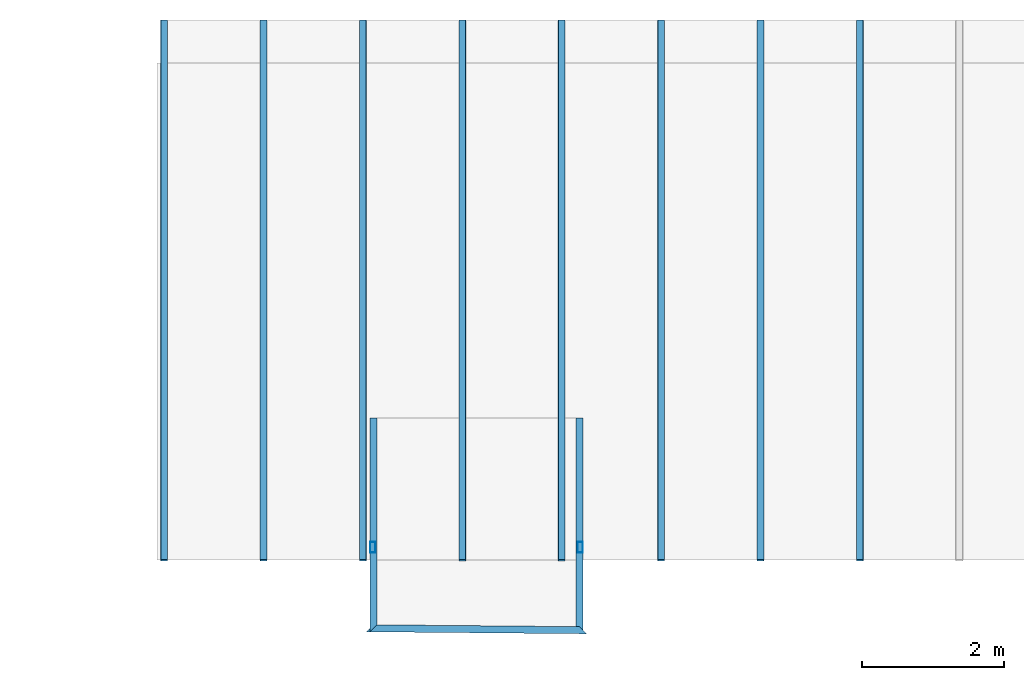
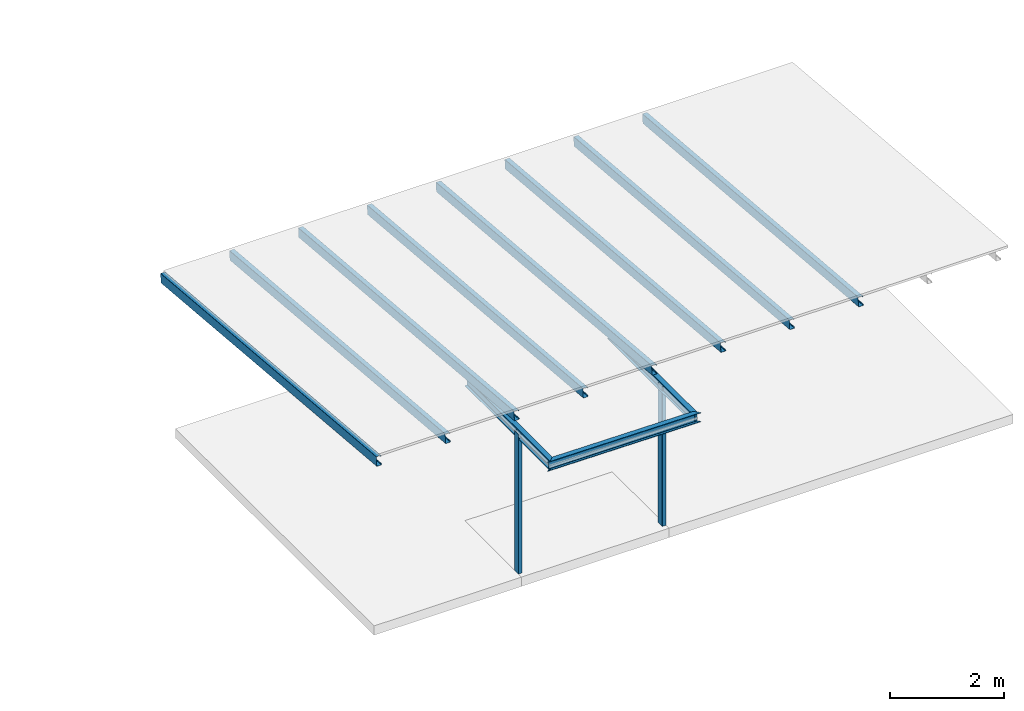
# One storey, part 3 of 8: 11 beams, 2 columns.
"""IFC4 building model written with IfcOpenShell, lengths in metres."""

from ifc_helpers import new_model, si_unit, frame, origin_with_axes, origin_2d_with_axis, place, context, subcontext, project, spatial, hollow_rectangle, i_section, c_section, extrude, clip, halfspace, material, material_profile, profile_set, profile_usage, type_object, element, save


model = new_model("IFC4")

# Units and contexts
model_context = context("Model", 3, precision=1e-05, world=origin_with_axes())
plan_context = context("Plan", 2, precision=1e-05, world=origin_2d_with_axis())
body_context = subcontext(model_context, "Body", "Model", "MODEL_VIEW")
ifc_project = project(units=[si_unit("VOLUMEUNIT", "CUBIC_METRE"), si_unit("LENGTHUNIT", "METRE"), si_unit("AREAUNIT", "SQUARE_METRE")], contexts=[model_context, plan_context])

# Site, building, storey
site_placement = place(None, origin_with_axes())
site = spatial("IfcSite", under=ifc_project, at=site_placement)
building_placement = place(site_placement, origin_with_axes())
building = spatial("IfcBuilding", under=site, at=building_placement, Name="Building")
storey_placement = place(building_placement, frame((0.0, 0.0, 7.0), z_axis=(0.0, 0.0, 1.0), x_axis=(1.0, 0.0, 0.0)))
storey = spatial("IfcBuildingStorey", under=building, at=storey_placement, Name="Level 2")

# Columns
ifc_material = material()
ifc_material_profile_1 = material_profile(ifc_material, hollow_rectangle(XDim=0.075, YDim=0.15, WallThickness=0.002, InnerFilletRadius=0.005, OuterFilletRadius=0.005))
ifc_profile_set_1 = profile_set([ifc_material_profile_1])
ifc_profile_usage_1 = profile_usage(ifc_profile_set_1, cardinal=5)
column_type = type_object("IfcColumnType", Name="C3", PredefinedType="NOTDEFINED", material=ifc_profile_set_1)
column_1_placement = place(storey_placement, frame((-0.03749847412109375, 0.18234758079051971, -7.0), z_axis=(0.0, 0.0, 1.0), x_axis=(1.0, 0.0, 0.0)))
element("IfcColumn", 1, at=column_1_placement, inside=storey, type_object=column_type, material=ifc_profile_usage_1, Name="Column", context=body_context, shape_type="SweptSolid", body=[
    extrude(hollow_rectangle(XDim=0.075, YDim=0.15, WallThickness=0.002, InnerFilletRadius=0.005, OuterFilletRadius=0.005), origin_with_axes(), (0.0, 0.0, 1.0), 3.0),
])
ifc_profile_usage_2 = profile_usage(ifc_profile_set_1, cardinal=5)
column_2_placement = place(storey_placement, frame((-2.962498188018799, 0.18234653770923615, -7.000000208616257), z_axis=(0.0, 0.0, 1.0), x_axis=(1.0, 0.0, 0.0)))
element("IfcColumn", 2, at=column_2_placement, inside=storey, type_object=column_type, material=ifc_profile_usage_2, Name="Column", context=body_context, shape_type="SweptSolid", body=[
    extrude(hollow_rectangle(XDim=0.075, YDim=0.15, WallThickness=0.002, InnerFilletRadius=0.005, OuterFilletRadius=0.005), origin_with_axes(), (0.0, 0.0, 1.0), 3.0),
])

# Beams
ifc_material_profile_2 = material_profile(ifc_material, i_section(OverallWidth=0.1, OverallDepth=0.2, WebThickness=0.005, FlangeThickness=0.01, FilletRadius=0.005))
ifc_profile_set_2 = profile_set([ifc_material_profile_2])
ifc_profile_usage_3 = profile_usage(ifc_profile_set_2, cardinal=5)
beam_type_1 = type_object("IfcBeamType", Name="B1", PredefinedType="NOTDEFINED", material=ifc_profile_set_2)
beam_1_placement = place(storey_placement, frame((-2.950000286102295, 1.9999995231628418, -4.0), z_axis=(2.4169833068297445e-07, -0.9999999999999216, 3.1391647326015385e-07), x_axis=(0.9999999999999709, 2.4169833068298636e-07, -7.089306626548652e-14)))
element("IfcBeam", 3, at=beam_1_placement, inside=storey, type_object=beam_type_1, material=ifc_profile_usage_3, Name="Beam", context=body_context, shape_type="Clipping", body=[
    clip(extrude(i_section(OverallWidth=0.1, OverallDepth=0.2, WebThickness=0.005, FlangeThickness=0.01, FilletRadius=0.005), origin_with_axes(), (0.0, 0.0, 1.0), 3.2092926936012094), halfspace(frame((-0.04999971762299538, -3.0000011920928955, 3.0088346004486084), z_axis=(0.7038670182228088, -2.0181441584554705e-07, 0.7103317379951477), x_axis=(-2.8672236462378816e-07, -0.9999999999999588, 0.0)), False)),
])
ifc_profile_usage_4 = profile_usage(ifc_profile_set_2, cardinal=5)
beam_2_placement = place(storey_placement, frame((-3.2499897480010986, -0.9570047855377197, -3.999981641769409), z_axis=(0.9999581920805248, -0.009143776962454424, -7.371505304809526e-05), x_axis=(0.009143776987297651, 0.9999581947973658, -9.677141538333073e-09)))
element("IfcBeam", 4, at=beam_2_placement, inside=storey, type_object=beam_type_1, material=ifc_profile_usage_4, Name="Beam", context=body_context, shape_type="Clipping", body=[
    clip(clip(extrude(i_section(OverallWidth=0.1, OverallDepth=0.2, WebThickness=0.005, FlangeThickness=0.01, FilletRadius=0.005), origin_with_axes(), (0.0, 0.0, 1.0), 3.5001288946107785), halfspace(frame((-0.049999918788671494, -2.9997751712799072, 3.300807476043701), z_axis=(0.7103319764137268, 5.187707574805245e-05, 0.7038668394088745), x_axis=(7.303215585424923e-05, -0.9999999973331521, 0.0)), False)), halfspace(frame((-0.050000037997961044, -3.0000035762786865, 0.2006784975528717), z_axis=(0.7038658261299133, -5.2376588428160176e-05, -0.7103329300880432), x_axis=(-7.441274506979924e-05, -0.9999999972313717, 0.0)), False)),
])
ifc_profile_usage_5 = profile_usage(ifc_profile_set_2, cardinal=5)
beam_3_placement = place(storey_placement, frame((-0.04999832063913345, -1.2367253303527832, -4.000239849090576), z_axis=(-1.509963847598649e-07, 0.9999999972630798, 7.39852546551974e-05), x_axis=(-0.9999999999999887, -1.5099580252808492e-07, -7.949847002919252e-09)))
element("IfcBeam", 5, at=beam_3_placement, inside=storey, type_object=beam_type_1, material=ifc_profile_usage_5, Name="Beam", context=body_context, shape_type="Clipping", body=[
    clip(extrude(i_section(OverallWidth=0.1, OverallDepth=0.2, WebThickness=0.005, FlangeThickness=0.01, FilletRadius=0.005), origin_with_axes(), (0.0, 0.0, 1.0), 3.236725777241487), halfspace(frame((-0.04999999701976776, -2.9997756481170654, 0.19932077825069427), z_axis=(0.710332989692688, 5.209675509831868e-05, -0.7038663029670715), x_axis=(7.334131416414219e-05, -0.9999999973105258, 0.0)), False)),
])
ifc_material_profile_3 = material_profile(ifc_material, c_section(Depth=0.2, Width=0.1, WallThickness=0.0015, Girth=0.03, InternalFilletRadius=0.005))
ifc_profile_set_3 = profile_set([ifc_material_profile_3])
ifc_profile_usage_6 = profile_usage(ifc_profile_set_3, cardinal=5)
beam_type_2 = type_object("IfcBeamType", Name="B2", PredefinedType="NOTDEFINED", material=ifc_profile_set_3)
beam_4_placement = place(storey_placement, frame((-5.899998188018799, 7.599998474121094, -4.149428844451904), z_axis=(-6.250297840404884e-08, -0.9961946827825887, 0.08715591773192101), x_axis=(0.999999999999998, -6.274172648090814e-08, -1.309945346774719e-15)))
element("IfcBeam", 6, at=beam_4_placement, inside=storey, type_object=beam_type_2, material=ifc_profile_usage_6, Name="Beam", context=body_context, shape_type="SweptSolid", body=[
    extrude(c_section(Depth=0.2, Width=0.1, WallThickness=0.0015, Girth=0.03, InternalFilletRadius=0.005), origin_with_axes(), (0.0, 0.0, 1.0), 7.629030118250166),
])
ifc_profile_usage_7 = profile_usage(ifc_profile_set_3, cardinal=5)
beam_5_placement = place(storey_placement, frame((-4.499998092651367, 7.599998474121094, -4.149428844451904), z_axis=(-6.250298305638236e-08, -0.9961947032889531, 0.0871556833432633), x_axis=(0.999999999999998, -6.27417335863355e-08, 1.1715304223144732e-15)))
element("IfcBeam", 7, at=beam_5_placement, inside=storey, type_object=beam_type_2, material=ifc_profile_usage_7, Name="Beam", context=body_context, shape_type="SweptSolid", body=[
    extrude(c_section(Depth=0.2, Width=0.1, WallThickness=0.0015, Girth=0.03, InternalFilletRadius=0.005), origin_with_axes(), (0.0, 0.0, 1.0), 7.629030118250166),
])
ifc_profile_usage_8 = profile_usage(ifc_profile_set_3, cardinal=5)
beam_6_placement = place(storey_placement, frame((-3.0999982357025146, 7.599998474121094, -4.149428844451904), z_axis=(-6.250298305638236e-08, -0.9961947032889531, 0.0871556833432633), x_axis=(0.999999999999998, -6.27417335863355e-08, 1.1715304223144732e-15)))
element("IfcBeam", 8, at=beam_6_placement, inside=storey, type_object=beam_type_2, material=ifc_profile_usage_8, Name="Beam", context=body_context, shape_type="SweptSolid", body=[
    extrude(c_section(Depth=0.2, Width=0.1, WallThickness=0.0015, Girth=0.03, InternalFilletRadius=0.005), origin_with_axes(), (0.0, 0.0, 1.0), 7.629030118250166),
])
ifc_profile_usage_9 = profile_usage(ifc_profile_set_3, cardinal=5)
beam_7_placement = place(storey_placement, frame((-1.699998378753662, 7.5999979972839355, -4.149428844451904), z_axis=(-6.25029797028334e-08, -0.9961947034830787, 0.08715568112439352), x_axis=(0.999999999999998, -6.27417335863355e-08, 1.1715304223144732e-15)))
element("IfcBeam", 9, at=beam_7_placement, inside=storey, type_object=beam_type_2, material=ifc_profile_usage_9, Name="Beam", context=body_context, shape_type="SweptSolid", body=[
    extrude(c_section(Depth=0.2, Width=0.1, WallThickness=0.0015, Girth=0.03, InternalFilletRadius=0.005), origin_with_axes(), (0.0, 0.0, 1.0), 7.629030118250166),
])
ifc_profile_usage_10 = profile_usage(ifc_profile_set_3, cardinal=5)
beam_8_placement = place(storey_placement, frame((-0.29999828338623047, 7.5999979972839355, -4.149428844451904), z_axis=(-6.250298305638236e-08, -0.9961947032889531, 0.0871556833432633), x_axis=(0.999999999999998, -6.27417335863355e-08, 1.1715304223144732e-15)))
element("IfcBeam", 10, at=beam_8_placement, inside=storey, type_object=beam_type_2, material=ifc_profile_usage_10, Name="Beam", context=body_context, shape_type="SweptSolid", body=[
    extrude(c_section(Depth=0.2, Width=0.1, WallThickness=0.0015, Girth=0.03, InternalFilletRadius=0.005), origin_with_axes(), (0.0, 0.0, 1.0), 7.629030118250166),
])
ifc_profile_usage_11 = profile_usage(ifc_profile_set_3, cardinal=5)
beam_9_placement = place(storey_placement, frame((1.1000018119812012, 7.5999979972839355, -4.149428844451904), z_axis=(-6.25029797028334e-08, -0.9961947034830787, 0.08715568112439352), x_axis=(0.999999999999998, -6.27417335863355e-08, 1.1715304223144732e-15)))
element("IfcBeam", 11, at=beam_9_placement, inside=storey, type_object=beam_type_2, material=ifc_profile_usage_11, Name="Beam", context=body_context, shape_type="SweptSolid", body=[
    extrude(c_section(Depth=0.2, Width=0.1, WallThickness=0.0015, Girth=0.03, InternalFilletRadius=0.005), origin_with_axes(), (0.0, 0.0, 1.0), 7.629030118250166),
])
ifc_profile_usage_12 = profile_usage(ifc_profile_set_3, cardinal=5)
beam_10_placement = place(storey_placement, frame((2.5000014305114746, 7.5999979972839355, -4.149428844451904), z_axis=(-6.250298305638236e-08, -0.9961947032889531, 0.0871556833432633), x_axis=(0.999999999999998, -6.27417335863355e-08, 1.1715304223144732e-15)))
element("IfcBeam", 12, at=beam_10_placement, inside=storey, type_object=beam_type_2, material=ifc_profile_usage_12, Name="Beam", context=body_context, shape_type="SweptSolid", body=[
    extrude(c_section(Depth=0.2, Width=0.1, WallThickness=0.0015, Girth=0.03, InternalFilletRadius=0.005), origin_with_axes(), (0.0, 0.0, 1.0), 7.629030118250166),
])
ifc_profile_usage_13 = profile_usage(ifc_profile_set_3, cardinal=5)
beam_11_placement = place(storey_placement, frame((3.9000020027160645, 7.5999979972839355, -4.149428844451904), z_axis=(-6.25029797028334e-08, -0.9961947034830787, 0.08715568112439352), x_axis=(0.999999999999998, -6.27417335863355e-08, 1.1715304223144732e-15)))
element("IfcBeam", 13, at=beam_11_placement, inside=storey, type_object=beam_type_2, material=ifc_profile_usage_13, Name="Beam", context=body_context, shape_type="SweptSolid", body=[
    extrude(c_section(Depth=0.2, Width=0.1, WallThickness=0.0015, Girth=0.03, InternalFilletRadius=0.005), origin_with_axes(), (0.0, 0.0, 1.0), 7.629030118250166),
])

save(model, "model.ifc")
